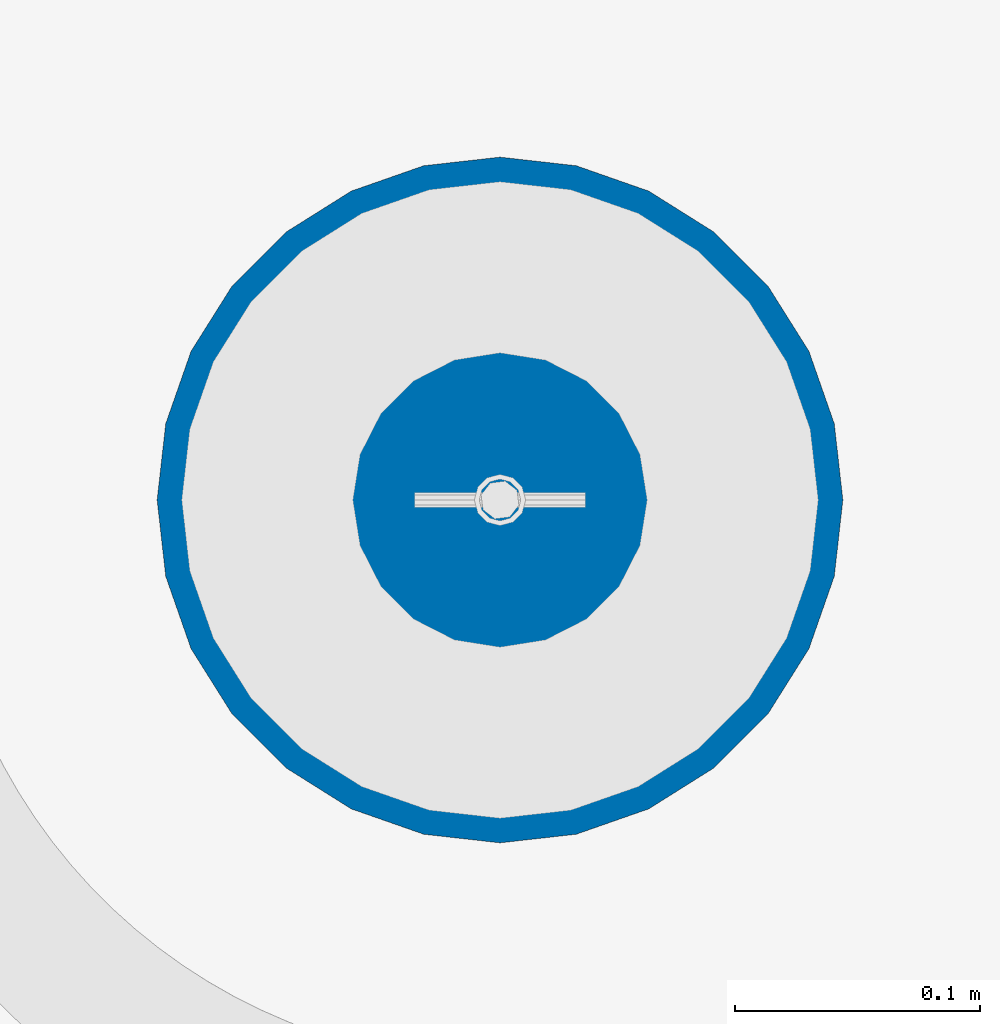
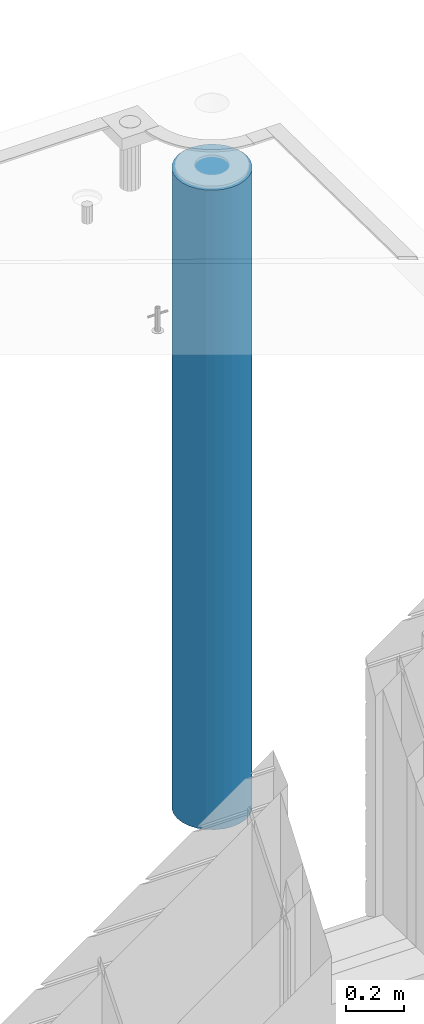
# One storey, part 7 of 352: 1 column, 1 element without a shape of its own.
"""IFC2X3 building model written with IfcOpenShell, lengths in millimetres."""

from ifc_helpers import new_model, si_unit, frame, origin_with_axes, place, context, subcontext, project, spatial, faceted_brep, material, type_object, element, aggregate, save


model = new_model("IFC2X3")

# Units and contexts
model_context = context("Model", 3, precision=1e-05, world=origin_with_axes())
body_context = subcontext(model_context, "Body", "Model", "MODEL_VIEW")
ifc_project = project(units=[si_unit("LENGTHUNIT", "METRE", prefix="MILLI"), si_unit("AREAUNIT", "SQUARE_METRE"), si_unit("VOLUMEUNIT", "CUBIC_METRE"), si_unit("MASSUNIT", "GRAM", prefix="KILO"), si_unit("TIMEUNIT", "SECOND"), si_unit("PLANEANGLEUNIT", "RADIAN"), si_unit("SOLIDANGLEUNIT", "STERADIAN"), si_unit("THERMODYNAMICTEMPERATUREUNIT", "DEGREE_CELSIUS"), si_unit("LUMINOUSINTENSITYUNIT", "LUMEN")], contexts=[model_context])

# Site, building, storey
site_placement = place(None, origin_with_axes())
site = spatial("IfcSite", under=ifc_project, at=site_placement, CompositionType="ELEMENT")
building_placement = place(site_placement, origin_with_axes())
building = spatial("IfcBuilding", under=site, at=building_placement, CompositionType="ELEMENT")
storey_placement = place(building_placement, origin_with_axes())
storey = spatial("IfcBuildingStorey", under=building, at=storey_placement, Name="6", CompositionType="ELEMENT", Elevation=0.0)

# Assembly, column
assembly_placement = place(storey_placement, origin_with_axes())
assembly = element("IfcElementAssembly", 1, at=assembly_placement, inside=storey, AssemblyPlace="NOTDEFINED", PredefinedType="REINFORCEMENT_UNIT")
ifc_material = material(Name="CONCRETE/C30/37")
column_type = type_object("IfcColumnType", Name="D280", PredefinedType="NOTDEFINED")
column_placement = place(assembly_placement, frame((35009.9987952044, 22669.984888838, 96725.0), z_axis=(-1.0, 3.00000001838171e-08, 0.0), x_axis=(0.0, 0.0, 1.0)))
column = element("IfcColumn", 2, at=column_placement, type_object=column_type, material=ifc_material, ObjectType="D280", context=body_context, shape_type="Brep", body=[
    faceted_brep([(0.0, -140.0, 0.0), (0.0, -136.489907705454, -31.1529307538876), (2710.0, -136.489907705454, -31.1529307538876), (2710.0, -140.0, 0.0), (0.0, -126.135641506338, -60.7437234764584), (2710.0, -126.135641506338, -60.7437234764584), (0.0, -109.456407545524, -87.2885722602223), (2710.0, -109.456407545524, -87.2885722602223), (0.0, -87.2885722602223, -109.456407545527), (2710.0, -87.2885722602223, -109.456407545527), (0.0, -60.7437234764584, -126.135641506342), (2710.0, -60.7437234764584, -126.135641506342), (0.0, -31.152930753884, -136.489907705458), (2710.0, -31.152930753884, -136.489907705458), (0.0, 0.0, -140.0), (2710.0, 0.0, -140.0), (0.0, 31.152930753884, -136.489907705458), (2710.0, 31.152930753884, -136.489907705458), (0.0, 60.7437234764584, -126.135641506342), (2710.0, 60.7437234764584, -126.135641506342), (0.0, 87.2885722602223, -109.456407545527), (2710.0, 87.2885722602223, -109.456407545527), (0.0, 109.456407545524, -87.2885722602223), (2710.0, 109.456407545524, -87.2885722602223), (0.0, 126.135641506338, -60.7437234764584), (2710.0, 126.135641506338, -60.7437234764584), (0.0, 136.489907705454, -31.1529307538876), (2710.0, 136.489907705454, -31.1529307538876), (0.0, 140.0, 0.0), (2710.0, 140.0, 0.0), (0.0, 136.489907705454, 31.1529307538876), (2710.0, 136.489907705454, 31.1529307538876), (0.0, 126.135641506338, 60.7437234764584), (2710.0, 126.135641506338, 60.7437234764584), (0.0, 109.456407545524, 87.2885722602223), (2710.0, 109.456407545524, 87.2885722602223), (0.0, 87.2885722602223, 109.456407545527), (2710.0, 87.2885722602223, 109.456407545527), (0.0, 60.7437234764584, 126.135641506342), (2710.0, 60.7437234764584, 126.135641506342), (0.0, 31.152930753884, 136.489907705458), (2710.0, 31.152930753884, 136.489907705458), (0.0, 0.0, 140.0), (2710.0, 0.0, 140.0), (0.0, -31.152930753884, 136.489907705458), (2710.0, -31.152930753884, 136.489907705458), (0.0, -60.7437234764584, 126.135641506342), (2710.0, -60.7437234764584, 126.135641506342), (0.0, -87.2885722602223, 109.456407545527), (2710.0, -87.2885722602223, 109.456407545527), (0.0, -109.456407545524, 87.2885722602223), (2710.0, -109.456407545524, 87.2885722602223), (0.0, -126.135641506338, 60.7437234764584), (2710.0, -126.135641506338, 60.7437234764584), (0.0, -136.489907705454, 31.1529307538876), (2710.0, -136.489907705454, 31.1529307538876)], [[[0, 1, 2, 3]], [[1, 4, 5, 2]], [[4, 6, 7, 5]], [[6, 8, 9, 7]], [[8, 10, 11, 9]], [[10, 12, 13, 11]], [[12, 14, 15, 13]], [[14, 16, 17, 15]], [[16, 18, 19, 17]], [[18, 20, 21, 19]], [[20, 22, 23, 21]], [[22, 24, 25, 23]], [[24, 26, 27, 25]], [[26, 28, 29, 27]], [[28, 30, 31, 29]], [[30, 32, 33, 31]], [[32, 34, 35, 33]], [[34, 36, 37, 35]], [[36, 38, 39, 37]], [[38, 40, 41, 39]], [[40, 42, 43, 41]], [[42, 44, 45, 43]], [[44, 46, 47, 45]], [[46, 48, 49, 47]], [[48, 50, 51, 49]], [[50, 52, 53, 51]], [[52, 54, 55, 53]], [[54, 0, 3, 55]], [[5, 7, 9, 11, 13, 15, 17, 19, 21, 23, 25, 27, 29, 31, 33, 35, 37, 39, 41, 43, 45, 47, 49, 51, 53, 55, 3, 2]], [[54, 52, 50, 48, 46, 44, 42, 40, 38, 36, 34, 32, 30, 28, 26, 24, 22, 20, 18, 16, 14, 12, 10, 8, 6, 4, 1, 0]]]),
])
aggregate(assembly, [column])

save(model, "model.ifc")
